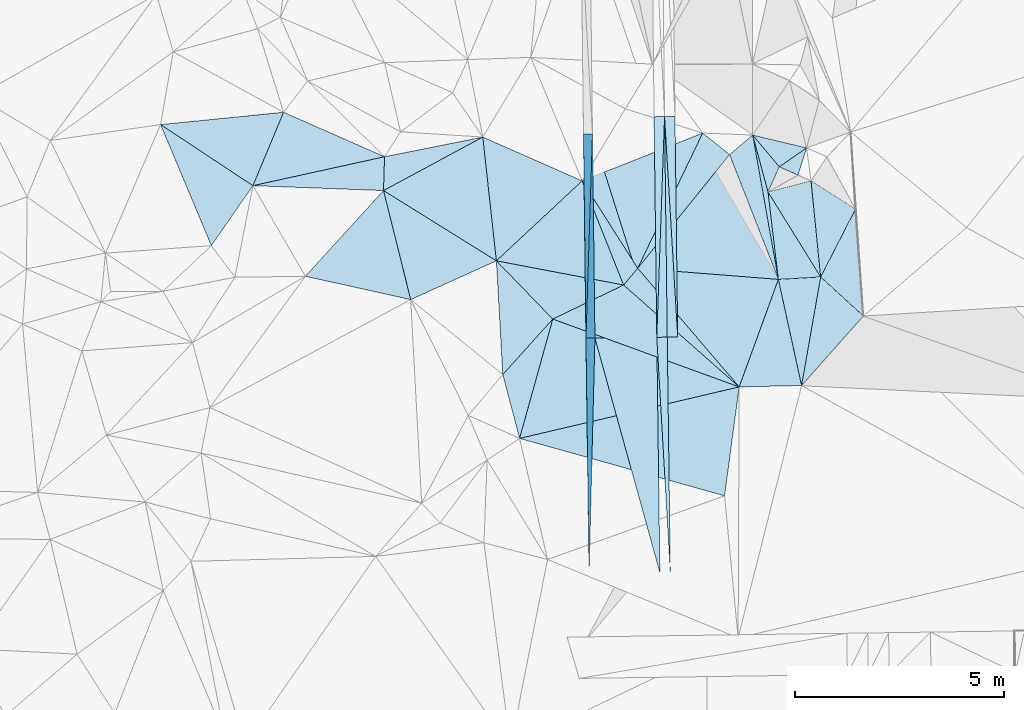
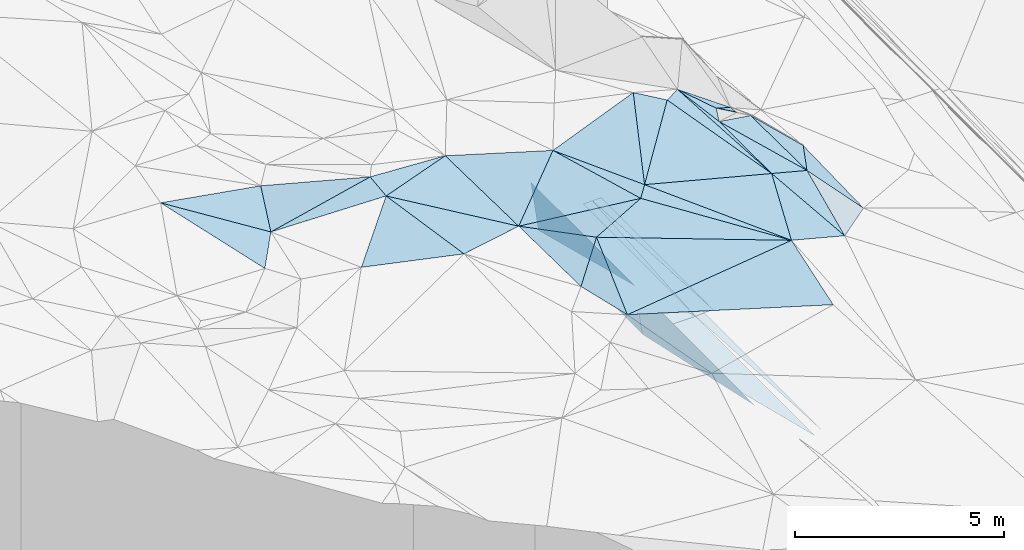
# One storey, part 12 of 275: 45 plates.
"""IFC2X3 building model written with IfcOpenShell, lengths in millimetres."""

from ifc_helpers import new_model, si_unit, frame, origin_with_axes, place, context, subcontext, project, spatial, polyline, outline, extrude, material, type_object, element, save


model = new_model("IFC2X3")

# Units and contexts
model_context = context("Model", 3, precision=1e-05, world=origin_with_axes())
body_context = subcontext(model_context, "Body", "Model", "MODEL_VIEW")
ifc_project = project(units=[si_unit("LENGTHUNIT", "METRE", prefix="MILLI"), si_unit("AREAUNIT", "SQUARE_METRE"), si_unit("VOLUMEUNIT", "CUBIC_METRE"), si_unit("MASSUNIT", "GRAM", prefix="KILO"), si_unit("TIMEUNIT", "SECOND"), si_unit("PLANEANGLEUNIT", "RADIAN"), si_unit("SOLIDANGLEUNIT", "STERADIAN"), si_unit("THERMODYNAMICTEMPERATUREUNIT", "DEGREE_CELSIUS"), si_unit("LUMINOUSINTENSITYUNIT", "LUMEN")], contexts=[model_context])

# Site, building, storey
site_placement = place(None, origin_with_axes())
site = spatial("IfcSite", under=ifc_project, at=site_placement, CompositionType="ELEMENT")
building_placement = place(site_placement, origin_with_axes())
building = spatial("IfcBuilding", under=site, at=building_placement, Name="Undefined", CompositionType="ELEMENT")
storey_placement = place(building_placement, origin_with_axes())
storey = spatial("IfcBuildingStorey", under=building, at=storey_placement, Name="Undefined", CompositionType="ELEMENT", Elevation=0.0)

# Plates
ifc_material = material()
plate_type_1 = type_object("IfcPlateType", PredefinedType="NOTDEFINED")
plate_1_placement = place(storey_placement, frame((-105311.534539102, 6777.27303504071, 42848.6392914802), z_axis=(-0.989907704704984, -0.00910865959501595, -0.141420537709669), x_axis=(0.0304010768781308, 0.961049442663291, -0.274699368913049)))
element("IfcPlate", 1, at=plate_1_placement, inside=storey, type_object=plate_type_1, material=ifc_material, Name="00_PR", context=body_context, shape_type="SweptSolid", body=[
    extrude(outline(polyline([(0.0, 0.0), (5085.4248046875, -1.4915713109076e-09), (421.161773681641, 1455.52087402344), (0.0, 0.0)])), frame((-8.85201319254618e-08, 2.18876761149539e-07, -0.5000001331573), z_axis=(0.0, 0.0, 1.0), x_axis=(1.0, 0.0, 0.0)), (0.0, 0.0, 1.0), 1.0),
])
plate_2_placement = place(storey_placement, frame((-105156.932144304, 11664.6177710189, 41451.6762918623), z_axis=(-0.989907704704984, -0.00910865959501595, -0.141420537709669), x_axis=(-0.03040107687677, -0.961049442663311, 0.274699368913131)))
element("IfcPlate", 2, at=plate_2_placement, inside=storey, type_object=plate_type_1, material=ifc_material, Name="00_PR", context=body_context, shape_type="SweptSolid", body=[
    extrude(outline(polyline([(0.0, 0.0), (5085.4248046875, -1.4915713109076e-09), (420.995239257813, 1455.56896972656), (0.0, 0.0)])), frame((-8.85201319254618e-08, 2.18876761149539e-07, -0.5000001331573), z_axis=(0.0, 0.0, 1.0), x_axis=(1.0, 0.0, 0.0)), (0.0, 0.0, 1.0), 1.0),
])
plate_type_2 = type_object("IfcPlateType", PredefinedType="NOTDEFINED")
plate_3_placement = place(storey_placement, frame((-103681.14404474, 12075.1999108277, 41459.4977358279), z_axis=(0.049675548596903, 0.0216651002195111, -0.998530401792592), x_axis=(0.998683480273055, 0.0117277551140836, 0.0499376209854073)))
element("IfcPlate", 3, at=plate_3_placement, inside=storey, type_object=plate_type_2, material=ifc_material, Name="00_PR", context=body_context, shape_type="SweptSolid", body=[
    extrude(outline(polyline([(0.0, 0.0), (250.312271118164, 1.46246748045087e-09), (-3.24399423599243, 5278.095703125), (0.0, 0.0)])), frame((-8.85201319254618e-08, 2.18876761149539e-07, -0.5000001331573), z_axis=(0.0, 0.0, 1.0), x_axis=(1.0, 0.0, 0.0)), (0.0, 0.0, 1.0), 1.0),
])
plate_4_placement = place(storey_placement, frame((-103431.161307653, 12078.1355123052, 41471.9977351904), z_axis=(0.0496571598516106, 0.0216657678600661, -0.998531301952275), x_axis=(0.0121785501104565, -0.99970349708119, -0.0210855600078803)))
element("IfcPlate", 4, at=plate_4_placement, inside=storey, type_object=plate_type_2, material=ifc_material, Name="00_PR", context=body_context, shape_type="SweptSolid", body=[
    extrude(outline(polyline([(0.0, 0.0), (5277.87744140625, -2.03726813197136e-10), (5278.25048828125, 250.311660766602), (0.0, 0.0)])), frame((-8.85201319254618e-08, 2.18876761149539e-07, -0.5000001331573), z_axis=(0.0, 0.0, 1.0), x_axis=(1.0, 0.0, 0.0)), (0.0, 0.0, 1.0), 1.0),
])
plate_5_placement = place(storey_placement, frame((-103616.864139286, 6798.66814611104, 41348.2107373969), z_axis=(0.0496542488797176, 0.0218785899681712, -0.998526806284737), x_axis=(0.998672792669044, 0.0126047731065468, 0.0499376899500204)))
element("IfcPlate", 5, at=plate_5_placement, inside=storey, type_object=plate_type_2, material=ifc_material, Name="00_PR", context=body_context, shape_type="SweptSolid", body=[
    extrude(outline(polyline([(0.0, 0.0), (250.311935424805, 6.73026079311967e-10), (246.953109741211, 5631.4130859375), (0.0, 0.0)])), frame((-8.85201319254618e-08, 2.18876761149539e-07, -0.5000001331573), z_axis=(0.0, 0.0, 1.0), x_axis=(1.0, 0.0, 0.0)), (0.0, 0.0, 1.0), 1.0),
])
plate_6_placement = place(storey_placement, frame((-103431.196251887, 12078.135100102, 41471.9972120583), z_axis=(-0.020237745679779, 0.0208372426819677, -0.999578032455302), x_axis=(0.999731085484492, 0.0117437361223175, -0.0199960340540243)))
element("IfcPlate", 6, at=plate_6_placement, inside=storey, type_object=plate_type_2, material=ifc_material, Name="00_PR", context=body_context, shape_type="SweptSolid", body=[
    extrude(outline(polyline([(0.0, 0.0), (250.049530029297, -4.94765117764473e-10), (254.571212768555, 5277.65771484375), (0.0, 0.0)])), frame((-8.85201319254618e-08, 2.18876761149539e-07, -0.5000001331573), z_axis=(0.0, 0.0, 1.0), x_axis=(1.0, 0.0, 0.0)), (0.0, 0.0, 1.0), 1.0),
])
plate_7_placement = place(storey_placement, frame((-103116.939240419, 6804.97696331954, 41355.7102121323), z_axis=(-0.0202560501928587, 0.0208361447954981, -0.999577684575164), x_axis=(-0.999720480409342, -0.0126143201234942, 0.0199959990482437)))
element("IfcPlate", 7, at=plate_7_placement, inside=storey, type_object=plate_type_2, material=ifc_material, Name="00_PR", context=body_context, shape_type="SweptSolid", body=[
    extrude(outline(polyline([(0.0, 0.0), (250.050018310547, 2.20097717829049e-10), (249.977157592773, 5277.87744140625), (0.0, 0.0)])), frame((-8.85201319254618e-08, 2.18876761149539e-07, -0.5000001331573), z_axis=(0.0, 0.0, 1.0), x_axis=(1.0, 0.0, 0.0)), (0.0, 0.0, 1.0), 1.0),
])
plate_type_3 = type_object("IfcPlateType", PredefinedType="NOTDEFINED")
plate_8_placement = place(storey_placement, frame((-106899.375949189, 4379.93959712704, 44009.5043430276), z_axis=(0.118877986441834, 0.0572390628680032, -0.991257642604347), x_axis=(-0.254442758458782, 0.966756584332533, 0.0253098660126992)))
element("IfcPlate", 8, at=plate_8_placement, inside=storey, type_object=plate_type_3, material=ifc_material, Name="00", context=body_context, shape_type="SweptSolid", body=[
    extrude(outline(polyline([(0.0, 0.0), (1580.41137695313, -2.11002770811319e-09), (2564.39575195313, 1506.6435546875), (0.0, 0.0)])), frame((-8.85201319254618e-08, 2.18876761149539e-07, -0.5000001331573), z_axis=(0.0, 0.0, 1.0), x_axis=(1.0, 0.0, 0.0)), (0.0, 0.0, 1.0), 1.0),
])
plate_type_4 = type_object("IfcPlateType", PredefinedType="NOTDEFINED")
plate_9_placement = place(storey_placement, frame((-98673.3346984324, 7308.29864070319, 42475.6112736278), z_axis=(-0.626266223391294, 0.0581544191839924, -0.777437252110148), x_axis=(-0.620500105248442, 0.56654435298623, 0.542224229895794)))
element("IfcPlate", 9, at=plate_9_placement, inside=storey, type_object=plate_type_4, material=ifc_material, Name="00", context=body_context, shape_type="SweptSolid", body=[
    extrude(outline(polyline([(0.0, 0.0), (1648.76440429688, 4.05270839110017e-09), (1754.3828125, 1905.32006835938), (0.0, 0.0)])), frame((-8.85201319254618e-08, 2.18876761149539e-07, -0.5000001331573), z_axis=(0.0, 0.0, 1.0), x_axis=(1.0, 0.0, 0.0)), (0.0, 0.0, 1.0), 1.0),
])
plate_type_5 = type_object("IfcPlateType", PredefinedType="NOTDEFINED")
plate_10_placement = place(storey_placement, frame((-103616.889101531, 6798.66775004432, 41348.2101130017), z_axis=(-0.000276400419123975, 0.0210828808791498, -0.999777693158156), x_axis=(-0.301591484977153, 0.953223562598078, 0.0201845459969806)))
element("IfcPlate", 10, at=plate_10_placement, inside=storey, type_object=plate_type_5, material=ifc_material, Name="00_PR", context=body_context, shape_type="SweptSolid", body=[
    extrude(outline(polyline([(0.0, 0.0), (5104.7470703125, 9.18225850909948e-09), (5051.34716796875, 1530.42419433594), (0.0, 0.0)])), frame((-8.85201319254618e-08, 2.18876761149539e-07, -0.5000001331573), z_axis=(0.0, 0.0, 1.0), x_axis=(1.0, 0.0, 0.0)), (0.0, 0.0, 1.0), 1.0),
])
plate_11_placement = place(storey_placement, frame((-105096.771078439, 6779.99218978298, 41348.2101130105), z_axis=(-0.0002660993093648, 0.021086138753576, -0.999777627246991), x_axis=(-0.0122114461021662, 0.999703048210039, 0.0210878160000028)))
element("IfcPlate", 11, at=plate_11_placement, inside=storey, type_object=plate_type_5, material=ifc_material, Name="00_PR", context=body_context, shape_type="SweptSolid", body=[
    extrude(outline(polyline([(0.0, 0.0), (4886.091796875, -2.38651409745216e-09), (0.598517000675201, 1479.99975585938), (0.0, 0.0)])), frame((-8.85201319254618e-08, 2.18876761149539e-07, -0.5000001331573), z_axis=(0.0, 0.0, 1.0), x_axis=(1.0, 0.0, 0.0)), (0.0, 0.0, 1.0), 1.0),
])
plate_12_placement = place(storey_placement, frame((-103543.210280673, 1168.77483800514, 41228.5231136307), z_axis=(-0.000268178566167329, 0.021250884903845, -0.999774138478817), x_axis=(-0.266772507193369, 0.963540364283153, 0.020552270017032)))
element("IfcPlate", 12, at=plate_12_placement, inside=storey, type_object=plate_type_5, material=ifc_material, Name="00_PR", context=body_context, shape_type="SweptSolid", body=[
    extrude(outline(polyline([(0.0, 0.0), (5823.54150390625, 9.89530235528946e-09), (5446.74462890625, 1431.2314453125), (0.0, 0.0)])), frame((-8.85201319254618e-08, 2.18876761149539e-07, -0.5000001331573), z_axis=(0.0, 0.0, 1.0), x_axis=(1.0, 0.0, 0.0)), (0.0, 0.0, 1.0), 1.0),
])
plate_type_6 = type_object("IfcPlateType", PredefinedType="NOTDEFINED")
plate_13_placement = place(storey_placement, frame((-105097.265896179, 6779.97667364757, 41348.6392917075), z_axis=(-0.989899562754256, -0.00994924521578573, -0.141420890177402), x_axis=(-0.0242256038924693, -0.970991788057475, 0.237882466022597)))
element("IfcPlate", 13, at=plate_13_placement, inside=storey, type_object=plate_type_6, material=ifc_material, Name="00_PR", context=body_context, shape_type="SweptSolid", body=[
    extrude(outline(polyline([(0.0, 0.0), (5802.5, -2.25554686039686e-09), (364.640106201172, 1470.69909667969), (0.0, 0.0)])), frame((-8.85201319254618e-08, 2.18876761149539e-07, -0.5000001331573), z_axis=(0.0, 0.0, 1.0), x_axis=(1.0, 0.0, 0.0)), (0.0, 0.0, 1.0), 1.0),
])
plate_type_7 = type_object("IfcPlateType", PredefinedType="NOTDEFINED")
plate_14_placement = place(storey_placement, frame((-101322.069498458, 11637.9859883481, 44252.5355389453), z_axis=(-0.358408016384368, 0.0933613736969055, -0.928885002404953), x_axis=(0.172632840587883, -0.971199400939211, -0.164224316000632)))
element("IfcPlate", 14, at=plate_14_placement, inside=storey, type_object=plate_type_7, material=ifc_material, Name="00", context=body_context, shape_type="SweptSolid", body=[
    extrude(outline(polyline([(0.0, 0.0), (3556.11157226563, -4.51109372079372e-10), (330.488220214844, 666.552001953125), (0.0, 0.0)])), frame((-8.85201319254618e-08, 2.18876761149539e-07, -0.5000001331573), z_axis=(0.0, 0.0, 1.0), x_axis=(1.0, 0.0, 0.0)), (0.0, 0.0, 1.0), 1.0),
])
plate_type_8 = type_object("IfcPlateType", PredefinedType="NOTDEFINED")
plate_15_placement = place(storey_placement, frame((-100238.779923733, 10681.1407174191, 43779.5720859319), z_axis=(-0.431166749436411, -0.285802984600366, -0.855810661404707), x_axis=(-0.870555178164331, 0.381052098901154, 0.311340616839973)))
element("IfcPlate", 15, at=plate_15_placement, inside=storey, type_object=plate_type_8, material=ifc_material, Name="00", context=body_context, shape_type="SweptSolid", body=[
    extrude(outline(polyline([(0.0, 0.0), (513.906616210938, 2.33558239415288e-09), (-31.328649520874, 751.011657714844), (0.0, 0.0)])), frame((-8.85201319254618e-08, 2.18876761149539e-07, -0.5000001331573), z_axis=(0.0, 0.0, 1.0), x_axis=(1.0, 0.0, 0.0)), (0.0, 0.0, 1.0), 1.0),
])
plate_type_9 = type_object("IfcPlateType", PredefinedType="NOTDEFINED")
plate_16_placement = place(storey_placement, frame((-107454.73803149, 8628.23388524601, 44219.5169216005), z_axis=(-0.250251994899827, 0.0634599074432098, -0.966098741949267), x_axis=(-0.891731081506079, -0.403743291430855, 0.204467681799787)))
element("IfcPlate", 16, at=plate_16_placement, inside=storey, type_object=plate_type_9, material=ifc_material, Name="00", context=body_context, shape_type="SweptSolid", body=[
    extrude(outline(polyline([(0.0, 0.0), (2298.65185546875, -1.21726770885289e-08), (1894.84985351563, 2680.79174804688), (0.0, 0.0)])), frame((-8.85201319254618e-08, 2.18876761149539e-07, -0.5000001331573), z_axis=(0.0, 0.0, 1.0), x_axis=(1.0, 0.0, 0.0)), (0.0, 0.0, 1.0), 1.0),
])
plate_type_10 = type_object("IfcPlateType", PredefinedType="NOTDEFINED")
plate_17_placement = place(storey_placement, frame((-100686.218178498, 10877.0550810528, 43939.5824616789), z_axis=(-0.539563084883728, -0.107457671201689, -0.83505959447854), x_axis=(-0.611580337436182, 0.731684808238326, 0.301009687974806)))
element("IfcPlate", 17, at=plate_17_placement, inside=storey, type_object=plate_type_10, material=ifc_material, Name="00", context=body_context, shape_type="SweptSolid", body=[
    extrude(outline(polyline([(0.0, 0.0), (1039.83361816406, 3.23052518069744e-09), (-212.543609619141, 903.396484375), (0.0, 0.0)])), frame((-8.85201319254618e-08, 2.18876761149539e-07, -0.5000001331573), z_axis=(0.0, 0.0, 1.0), x_axis=(1.0, 0.0, 0.0)), (0.0, 0.0, 1.0), 1.0),
])
plate_type_11 = type_object("IfcPlateType", PredefinedType="NOTDEFINED")
plate_18_placement = place(storey_placement, frame((-105402.89860283, 10541.1997784355, 44559.5023324568), z_axis=(0.00287089548697418, 0.097012839862263, -0.995278989460223), x_axis=(0.534646845404207, -0.841236964478008, -0.0804557039317723)))
element("IfcPlate", 18, at=plate_18_placement, inside=storey, type_object=plate_type_11, material=ifc_material, Name="00", context=body_context, shape_type="SweptSolid", body=[
    extrude(outline(polyline([(0.0, 0.0), (2485.83984375, -6.21366780251265e-09), (2645.78588867188, 499.817260742188), (0.0, 0.0)])), frame((-8.85201319254618e-08, 2.18876761149539e-07, -0.5000001331573), z_axis=(0.0, 0.0, 1.0), x_axis=(1.0, 0.0, 0.0)), (0.0, 0.0, 1.0), 1.0),
])
plate_type_12 = type_object("IfcPlateType", PredefinedType="NOTDEFINED")
plate_19_placement = place(storey_placement, frame((-100708.039436247, 8184.31991708845, 43668.5081416252), z_axis=(-0.10176336654217, 0.148249486077847, -0.983700313666545), x_axis=(-0.172632840193338, 0.971199401024251, 0.164224315912468)))
element("IfcPlate", 19, at=plate_19_placement, inside=storey, type_object=plate_type_12, material=ifc_material, Name="00", context=body_context, shape_type="SweptSolid", body=[
    extrude(outline(polyline([(0.0, 0.0), (3556.11157226563, -4.51109372079372e-10), (2130.89672851563, 122.134048461914), (0.0, 0.0)])), frame((-8.85201319254618e-08, 2.18876761149539e-07, -0.5000001331573), z_axis=(0.0, 0.0, 1.0), x_axis=(1.0, 0.0, 0.0)), (0.0, 0.0, 1.0), 1.0),
])
plate_type_13 = type_object("IfcPlateType", PredefinedType="NOTDEFINED")
plate_20_placement = place(storey_placement, frame((-99696.2502533209, 8242.40960016099, 43369.5317261071), z_axis=(-0.340428152315741, 0.0837690067391531, -0.936531594032378), x_axis=(-0.508731502324898, 0.821238178169803, 0.258379784926366)))
element("IfcPlate", 20, at=plate_20_placement, inside=storey, type_object=plate_type_13, material=ifc_material, Name="00", context=body_context, shape_type="SweptSolid", body=[
    extrude(outline(polyline([(0.0, 0.0), (2476.97387695313, 5.6170392781496e-09), (2083.99438476563, 1048.55480957031), (0.0, 0.0)])), frame((-8.85201319254618e-08, 2.18876761149539e-07, -0.5000001331573), z_axis=(0.0, 0.0, 1.0), x_axis=(1.0, 0.0, 0.0)), (0.0, 0.0, 1.0), 1.0),
])
plate_type_14 = type_object("IfcPlateType", PredefinedType="NOTDEFINED")
plate_21_placement = place(storey_placement, frame((-100152.939018249, 5644.94776319653, 43192.5216678955), z_axis=(-0.264801575882705, 0.121424983426986, -0.956627460827773), x_axis=(-0.964235945462771, -0.021649415538222, 0.264159694662847)))
element("IfcPlate", 21, at=plate_21_placement, inside=storey, type_object=plate_type_14, material=ifc_material, Name="00", context=body_context, shape_type="SweptSolid", body=[
    extrude(outline(polyline([(0.0, 0.0), (1548.30590820313, 5.05679054185748e-09), (606.0908203125, 2572.11962890625), (0.0, 0.0)])), frame((-8.85201319254618e-08, 2.18876761149539e-07, -0.5000001331573), z_axis=(0.0, 0.0, 1.0), x_axis=(1.0, 0.0, 0.0)), (0.0, 0.0, 1.0), 1.0),
])
plate_type_15 = type_object("IfcPlateType", PredefinedType="NOTDEFINED")
plate_22_placement = place(storey_placement, frame((-100956.384255378, 10276.5847810361, 44009.5383786055), z_axis=(-0.379064172914386, 0.0629665458802271, -0.9232256316376), x_axis=(-0.255652731098491, 0.951726404651745, 0.169877990836204)))
element("IfcPlate", 22, at=plate_22_placement, inside=storey, type_object=plate_type_15, material=ifc_material, Name="00", context=body_context, shape_type="SweptSolid", body=[
    extrude(outline(polyline([(0.0, 0.0), (1430.43835449219, -1.17870513349772e-09), (490.583862304688, 444.890411376953), (0.0, 0.0)])), frame((-8.85201319254618e-08, 2.18876761149539e-07, -0.5000001331573), z_axis=(0.0, 0.0, 1.0), x_axis=(1.0, 0.0, 0.0)), (0.0, 0.0, 1.0), 1.0),
])
plate_type_16 = type_object("IfcPlateType", PredefinedType="NOTDEFINED")
plate_23_placement = place(storey_placement, frame((-102519.152049901, 11684.9191982441, 44549.5061837628), z_axis=(-0.110783938408556, 0.111251216509545, -0.987598139840206), x_axis=(0.77140163336825, -0.616923780432751, -0.156027462881888)))
element("IfcPlate", 23, at=plate_23_placement, inside=storey, type_object=plate_type_16, material=ifc_material, Name="00", context=body_context, shape_type="SweptSolid", body=[
    extrude(outline(polyline([(0.0, 0.0), (833.186645507813, 2.25554686039686e-10), (825.985412597656, 3497.94921875), (0.0, 0.0)])), frame((-8.85201319254618e-08, 2.18876761149539e-07, -0.5000001331573), z_axis=(0.0, 0.0, 1.0), x_axis=(1.0, 0.0, 0.0)), (0.0, 0.0, 1.0), 1.0),
])
plate_type_17 = type_object("IfcPlateType", PredefinedType="NOTDEFINED")
plate_24_placement = place(storey_placement, frame((-110130.235532706, 11119.0642143201, 45089.5013637645), z_axis=(0.0123268294845498, 0.0735623200279889, -0.997214437494243), x_axis=(-0.0307243713770341, -0.996791447861311, -0.0739109090326888)))
element("IfcPlate", 24, at=plate_24_placement, inside=storey, type_object=plate_type_17, material=ifc_material, Name="00", context=body_context, shape_type="SweptSolid", body=[
    extrude(outline(polyline([(0.0, 0.0), (811.788146972656, 4.94765117764473e-10), (793.556762695313, 3126.2705078125), (0.0, 0.0)])), frame((-8.85201319254618e-08, 2.18876761149539e-07, -0.5000001331573), z_axis=(0.0, 0.0, 1.0), x_axis=(1.0, 0.0, 0.0)), (0.0, 0.0, 1.0), 1.0),
])
plate_type_18 = type_object("IfcPlateType", PredefinedType="NOTDEFINED")
plate_25_placement = place(storey_placement, frame((-99927.4203669078, 10545.6507572962, 43659.6016722024), z_axis=(-0.603143476425068, 0.0398025700156765, -0.79663900373132), x_axis=(0.702389133977225, -0.446780994797186, -0.554108515688723)))
element("IfcPlate", 25, at=plate_25_placement, inside=storey, type_object=plate_type_18, material=ifc_material, Name="00", context=body_context, shape_type="SweptSolid", body=[
    extrude(outline(polyline([(0.0, 0.0), (1515.94860839844, -7.26140569895506e-09), (1352.02478027344, 1901.19152832031), (0.0, 0.0)])), frame((-8.85201319254618e-08, 2.18876761149539e-07, -0.5000001331573), z_axis=(0.0, 0.0, 1.0), x_axis=(1.0, 0.0, 0.0)), (0.0, 0.0, 1.0), 1.0),
])
plate_type_19 = type_object("IfcPlateType", PredefinedType="NOTDEFINED")
plate_26_placement = place(storey_placement, frame((-107779.911550304, 11589.6351528228, 44599.513654365), z_axis=(-0.218553867247165, 0.0788561700006157, -0.972633492927394), x_axis=(-0.869391685502058, -0.468390336414707, 0.15738039882148)))
element("IfcPlate", 26, at=plate_26_placement, inside=storey, type_object=plate_type_19, material=ifc_material, Name="00", context=body_context, shape_type="SweptSolid", body=[
    extrude(outline(polyline([(0.0, 0.0), (2732.2333984375, 7.53789208829403e-09), (2340.978515625, 711.280212402344), (0.0, 0.0)])), frame((-8.85201319254618e-08, 2.18876761149539e-07, -0.5000001331573), z_axis=(0.0, 0.0, 1.0), x_axis=(1.0, 0.0, 0.0)), (0.0, 0.0, 1.0), 1.0),
])
plate_type_20 = type_object("IfcPlateType", PredefinedType="NOTDEFINED")
plate_27_placement = place(storey_placement, frame((-99696.3631426029, 8242.44507972654, 43369.5951862125), z_axis=(-0.566205723425485, 0.154727751885412, -0.809611265705159), x_axis=(0.620500105249706, -0.566544352987563, -0.542224229892955)))
element("IfcPlate", 27, at=plate_27_placement, inside=storey, type_object=plate_type_20, material=ifc_material, Name="00", context=body_context, shape_type="SweptSolid", body=[
    extrude(outline(polyline([(0.0, 0.0), (1648.76440429688, 4.05270839110017e-09), (1284.16284179688, 2310.35913085938), (0.0, 0.0)])), frame((-8.85201319254618e-08, 2.18876761149539e-07, -0.5000001331573), z_axis=(0.0, 0.0, 1.0), x_axis=(1.0, 0.0, 0.0)), (0.0, 0.0, 1.0), 1.0),
])
plate_type_21 = type_object("IfcPlateType", PredefinedType="NOTDEFINED")
plate_28_placement = place(storey_placement, frame((-107454.559423281, 8628.2361714643, 44219.5040195692), z_axis=(0.107050397893271, 0.068008536030492, -0.991924922228432), x_axis=(0.695183663893955, -0.718369995981389, 0.0257725111053699)))
element("IfcPlate", 28, at=plate_28_placement, inside=storey, type_object=plate_type_21, material=ifc_material, Name="00", context=body_context, shape_type="SweptSolid", body=[
    extrude(outline(polyline([(0.0, 0.0), (1940.05151367188, 5.0495145842433e-09), (2056.28564453125, 1795.74206542969), (0.0, 0.0)])), frame((-8.85201319254618e-08, 2.18876761149539e-07, -0.5000001331573), z_axis=(0.0, 0.0, 1.0), x_axis=(1.0, 0.0, 0.0)), (0.0, 0.0, 1.0), 1.0),
])
plate_type_22 = type_object("IfcPlateType", PredefinedType="NOTDEFINED")
plate_29_placement = place(storey_placement, frame((-100152.950401821, 5644.94472752284, 43192.5245871119), z_axis=(-0.287565944820449, 0.11535354525011, -0.950788823544826), x_axis=(-0.21009215455279, 0.960944933764837, 0.18012806796016)))
element("IfcPlate", 29, at=plate_29_placement, inside=storey, type_object=plate_type_22, material=ifc_material, Name="00", context=body_context, shape_type="SweptSolid", body=[
    extrude(outline(polyline([(0.0, 0.0), (2642.56420898438, 7.71251507103443e-10), (2431.9638671875, 1035.56042480469), (0.0, 0.0)])), frame((-8.85201319254618e-08, 2.18876761149539e-07, -0.5000001331573), z_axis=(0.0, 0.0, 1.0), x_axis=(1.0, 0.0, 0.0)), (0.0, 0.0, 1.0), 1.0),
])
plate_type_23 = type_object("IfcPlateType", PredefinedType="NOTDEFINED")
plate_30_placement = place(storey_placement, frame((-104410.703975727, 8049.56722336791, 44319.5002318033), z_axis=(0.0318846638023713, -0.00500213999710401, -0.999479037703973), x_axis=(-0.900925460907784, -0.433159553634864, -0.026572824143154)))
element("IfcPlate", 30, at=plate_30_placement, inside=storey, type_object=plate_type_23, material=ifc_material, Name="00", context=body_context, shape_type="SweptSolid", body=[
    extrude(outline(polyline([(0.0, 0.0), (1881.62158203125, -1.03900674730539e-08), (2494.337890625, 1840.75500488281), (0.0, 0.0)])), frame((-8.85201319254618e-08, 2.18876761149539e-07, -0.5000001331573), z_axis=(0.0, 0.0, 1.0), x_axis=(1.0, 0.0, 0.0)), (0.0, 0.0, 1.0), 1.0),
])
plate_type_24 = type_object("IfcPlateType", PredefinedType="NOTDEFINED")
plate_31_placement = place(storey_placement, frame((-99696.2239599939, 8242.42809552482, 43369.5249359947), z_axis=(-0.287668091113385, 0.120718513487861, -0.950091632347355), x_axis=(-0.957559133327413, -0.0550002085666582, 0.282940776910784)))
element("IfcPlate", 31, at=plate_31_placement, inside=storey, type_object=plate_type_24, material=ifc_material, Name="00", context=body_context, shape_type="SweptSolid", body=[
    extrude(outline(polyline([(0.0, 0.0), (1056.75830078125, -5.71526470594108e-09), (1275.83581542969, 2123.12109375), (0.0, 0.0)])), frame((-8.85201319254618e-08, 2.18876761149539e-07, -0.5000001331573), z_axis=(0.0, 0.0, 1.0), x_axis=(1.0, 0.0, 0.0)), (0.0, 0.0, 1.0), 1.0),
])
plate_type_25 = type_object("IfcPlateType", PredefinedType="NOTDEFINED")
plate_32_placement = place(storey_placement, frame((-104410.692474105, 8049.62840952679, 44319.5041863406), z_axis=(0.0548871623162619, 0.117369166394397, -0.991570410103465), x_axis=(-0.981895854534504, 0.186654651482314, -0.0322578971412091)))
element("IfcPlate", 32, at=plate_32_placement, inside=storey, type_object=plate_type_25, material=ifc_material, Name="00", context=body_context, shape_type="SweptSolid", body=[
    extrude(outline(polyline([(0.0, 0.0), (3100.01611328125, 9.32413968257606e-09), (1431.54089355469, 2280.50219726563), (0.0, 0.0)])), frame((-8.85201319254618e-08, 2.18876761149539e-07, -0.5000001331573), z_axis=(0.0, 0.0, 1.0), x_axis=(1.0, 0.0, 0.0)), (0.0, 0.0, 1.0), 1.0),
])
plate_type_26 = type_object("IfcPlateType", PredefinedType="NOTDEFINED")
plate_33_placement = place(storey_placement, frame((-104073.950039461, 8450.01873384058, 44359.5117055336), z_axis=(-0.192919817678208, 0.0957442103405234, -0.976532124475829), x_axis=(0.976654131708035, -0.0771039473676926, -0.200503586795711)))
element("IfcPlate", 33, at=plate_33_placement, inside=storey, type_object=plate_type_26, material=ifc_material, Name="00", context=body_context, shape_type="SweptSolid", body=[
    extrude(outline(polyline([(0.0, 0.0), (3446.32250976563, -1.1098563845735e-08), (2742.27758789063, 2647.24194335938), (0.0, 0.0)])), frame((-8.85201319254618e-08, 2.18876761149539e-07, -0.5000001331573), z_axis=(0.0, 0.0, 1.0), x_axis=(1.0, 0.0, 0.0)), (0.0, 0.0, 1.0), 1.0),
])
plate_type_27 = type_object("IfcPlateType", PredefinedType="NOTDEFINED")
plate_34_placement = place(storey_placement, frame((-112546.834517471, 12182.8389268325, 45029.5187186239), z_axis=(-0.244129381651212, 0.118266914043218, -0.962503912749081), x_axis=(-0.384902091329228, -0.922822765980292, -0.0157646020840735)))
element("IfcPlate", 34, at=plate_34_placement, inside=storey, type_object=plate_type_27, material=ifc_material, Name="00", context=body_context, shape_type="SweptSolid", body=[
    extrude(outline(polyline([(0.0, 0.0), (1902.99768066406, 4.10364009439945e-09), (1393.22290039063, 2702.87426757813), (0.0, 0.0)])), frame((-8.85201319254618e-08, 2.18876761149539e-07, -0.5000001331573), z_axis=(0.0, 0.0, 1.0), x_axis=(1.0, 0.0, 0.0)), (0.0, 0.0, 1.0), 1.0),
])
plate_type_28 = type_object("IfcPlateType", PredefinedType="NOTDEFINED")
plate_35_placement = place(storey_placement, frame((-101645.786936315, 5611.45660162848, 43601.5104125406), z_axis=(-0.096446995642583, 0.178956721677644, -0.97911820981836), x_axis=(-0.736204207457864, 0.649196099572995, 0.191174760940215)))
element("IfcPlate", 35, at=plate_35_placement, inside=storey, type_object=plate_type_28, material=ifc_material, Name="00", context=body_context, shape_type="SweptSolid", body=[
    extrude(outline(polyline([(0.0, 0.0), (3755.72583007813, -1.90848368220031e-08), (3775.30932617188, 524.420166015625), (0.0, 0.0)])), frame((-8.85201319254618e-08, 2.18876761149539e-07, -0.5000001331573), z_axis=(0.0, 0.0, 1.0), x_axis=(1.0, 0.0, 0.0)), (0.0, 0.0, 1.0), 1.0),
])
plate_type_29 = type_object("IfcPlateType", PredefinedType="NOTDEFINED")
plate_36_placement = place(storey_placement, frame((-101876.46765877, 11170.9363494947, 44419.5161065221), z_axis=(-0.185179735338343, 0.170897767210733, -0.967730550712546), x_axis=(0.354725910643194, -0.906742951926296, -0.228006025030797)))
element("IfcPlate", 36, at=plate_36_placement, inside=storey, type_object=plate_type_29, material=ifc_material, Name="00", context=body_context, shape_type="SweptSolid", body=[
    extrude(outline(polyline([(0.0, 0.0), (3293.77270507813, 4.33647073805332e-09), (1701.31665039063, 3056.34130859375), (0.0, 0.0)])), frame((-8.85201319254618e-08, 2.18876761149539e-07, -0.5000001331573), z_axis=(0.0, 0.0, 1.0), x_axis=(1.0, 0.0, 0.0)), (0.0, 0.0, 1.0), 1.0),
])
plate_type_30 = type_object("IfcPlateType", PredefinedType="NOTDEFINED")
plate_37_placement = place(storey_placement, frame((-110155.199469361, 10309.9045624227, 45029.5039194873), z_axis=(-0.0321820030728838, 0.121228620482935, -0.992102787141545), x_axis=(0.240052862669518, -0.962624584105315, -0.125413449040517)))
element("IfcPlate", 37, at=plate_37_placement, inside=storey, type_object=plate_type_30, material=ifc_material, Name="00", context=body_context, shape_type="SweptSolid", body=[
    extrude(outline(polyline([(0.0, 0.0), (2711.03295898438, 1.01863406598568e-09), (1549.59387207031, 2311.02978515625), (0.0, 0.0)])), frame((-8.85201319254618e-08, 2.18876761149539e-07, -0.5000001331573), z_axis=(0.0, 0.0, 1.0), x_axis=(1.0, 0.0, 0.0)), (0.0, 0.0, 1.0), 1.0),
])
plate_38_placement = place(storey_placement, frame((-105402.879339181, 10541.2170891411, 44559.5047556066), z_axis=(0.0413966767688224, 0.13163614563228, -0.990433359855965), x_axis=(-0.726093784158543, -0.676985794052947, -0.120324774077613)))
element("IfcPlate", 38, at=plate_38_placement, inside=storey, type_object=plate_type_30, material=ifc_material, Name="00", context=body_context, shape_type="SweptSolid", body=[
    extrude(outline(polyline([(0.0, 0.0), (2825.68579101563, -8.58562998473644e-10), (1011.25897216797, 2393.2939453125), (0.0, 0.0)])), frame((-8.85201319254618e-08, 2.18876761149539e-07, -0.5000001331573), z_axis=(0.0, 0.0, 1.0), x_axis=(1.0, 0.0, 0.0)), (0.0, 0.0, 1.0), 1.0),
])
plate_type_31 = type_object("IfcPlateType", PredefinedType="NOTDEFINED")
plate_39_placement = place(storey_placement, frame((-107779.916637785, 11589.6453001737, 44599.5157567939), z_axis=(-0.228726293902936, 0.0991504195826286, -0.968428353970502), x_axis=(0.108276216632434, -0.98603620204161, -0.126526160042592)))
element("IfcPlate", 39, at=plate_39_placement, inside=storey, type_object=plate_type_31, material=ifc_material, Name="00", context=body_context, shape_type="SweptSolid", body=[
    extrude(outline(polyline([(0.0, 0.0), (3003.33154296875, -5.28234522789717e-09), (950.278076171875, 2561.65405273438), (0.0, 0.0)])), frame((-8.85201319254618e-08, 2.18876761149539e-07, -0.5000001331573), z_axis=(0.0, 0.0, 1.0), x_axis=(1.0, 0.0, 0.0)), (0.0, 0.0, 1.0), 1.0),
])
plate_type_32 = type_object("IfcPlateType", PredefinedType="NOTDEFINED")
plate_40_placement = place(storey_placement, frame((-115488.887690267, 11888.0549007793, 45739.5198218824), z_axis=(-0.266019143707704, 0.0840518309363356, -0.960296363055317), x_axis=(0.803327609185579, -0.531302730380074, -0.269039329858778)))
element("IfcPlate", 40, at=plate_40_placement, inside=storey, type_object=plate_type_32, material=ifc_material, Name="00", context=body_context, shape_type="SweptSolid", body=[
    extrude(outline(polyline([(0.0, 0.0), (2750.52734375, -8.9130480773747e-09), (2673.3056640625, 1750.63903808594), (0.0, 0.0)])), frame((-8.85201319254618e-08, 2.18876761149539e-07, -0.5000001331573), z_axis=(0.0, 0.0, 1.0), x_axis=(1.0, 0.0, 0.0)), (0.0, 0.0, 1.0), 1.0),
])
plate_type_33 = type_object("IfcPlateType", PredefinedType="NOTDEFINED")
plate_41_placement = place(storey_placement, frame((-102519.113090793, 11684.9007495797, 44549.5016291004), z_axis=(-0.0329545680169962, 0.0743785329973703, -0.996685421924076), x_axis=(-0.43258011540708, -0.900044372189196, -0.0528637100944801)))
element("IfcPlate", 41, at=plate_41_placement, inside=storey, type_object=plate_type_33, material=ifc_material, Name="00", context=body_context, shape_type="SweptSolid", body=[
    extrude(outline(polyline([(0.0, 0.0), (3594.14794921875, -1.19325704872608e-09), (2276.33911132813, 2107.79028320313), (0.0, 0.0)])), frame((-8.85201319254618e-08, 2.18876761149539e-07, -0.5000001331573), z_axis=(0.0, 0.0, 1.0), x_axis=(1.0, 0.0, 0.0)), (0.0, 0.0, 1.0), 1.0),
])
plate_type_34 = type_object("IfcPlateType", PredefinedType="NOTDEFINED")
plate_42_placement = place(storey_placement, frame((-106899.483536042, 4379.95207285851, 44009.5039948584), z_axis=(-0.0962999990970524, 0.0821905919093737, -0.991953132348245), x_axis=(0.970840179619645, 0.227563024538348, -0.0753950628294441)))
element("IfcPlate", 42, at=plate_42_placement, inside=storey, type_object=plate_type_34, material=ifc_material, Name="00", context=body_context, shape_type="SweptSolid", body=[
    extrude(outline(polyline([(0.0, 0.0), (5411.4951171875, -7.45421857573092e-09), (4493.21875, 2470.13891601563), (0.0, 0.0)])), frame((-8.85201319254618e-08, 2.18876761149539e-07, -0.5000001331573), z_axis=(0.0, 0.0, 1.0), x_axis=(1.0, 0.0, 0.0)), (0.0, 0.0, 1.0), 1.0),
])
plate_type_35 = type_object("IfcPlateType", PredefinedType="NOTDEFINED")
plate_43_placement = place(storey_placement, frame((-113279.166563922, 10426.6530914986, 44999.5001656692), z_axis=(0.0273207939312685, 0.00568108247297882, -0.99961057393412), x_axis=(0.384902091328643, 0.922822765980104, 0.0157646021093592)))
element("IfcPlate", 43, at=plate_43_placement, inside=storey, type_object=plate_type_35, material=ifc_material, Name="00", context=body_context, shape_type="SweptSolid", body=[
    extrude(outline(polyline([(0.0, 0.0), (1902.99768066406, 4.10364009439945e-09), (1852.39331054688, 2640.44287109375), (0.0, 0.0)])), frame((-8.85201319254618e-08, 2.18876761149539e-07, -0.5000001331573), z_axis=(0.0, 0.0, 1.0), x_axis=(1.0, 0.0, 0.0)), (0.0, 0.0, 1.0), 1.0),
])
plate_type_36 = type_object("IfcPlateType", PredefinedType="NOTDEFINED")
plate_44_placement = place(storey_placement, frame((-101645.774145858, 5611.4706728491, 43601.5121022076), z_axis=(-0.0707802564432016, 0.207074894041566, -0.975761314848826), x_axis=(-0.930536387974515, 0.338643046281293, 0.139366128814245)))
element("IfcPlate", 44, at=plate_44_placement, inside=storey, type_object=plate_type_36, material=ifc_material, Name="00", context=body_context, shape_type="SweptSolid", body=[
    extrude(outline(polyline([(0.0, 0.0), (4793.13037109375, 1.35951268021017e-08), (3498.66088867188, 1365.59484863281), (0.0, 0.0)])), frame((-8.85201319254618e-08, 2.18876761149539e-07, -0.5000001331573), z_axis=(0.0, 0.0, 1.0), x_axis=(1.0, 0.0, 0.0)), (0.0, 0.0, 1.0), 1.0),
])
plate_type_37 = type_object("IfcPlateType", PredefinedType="NOTDEFINED")
plate_45_placement = place(storey_placement, frame((-106105.973110776, 7234.58684519144, 44269.5062943226), z_axis=(-0.104572046381364, 0.118998908539997, -0.987372243321587), x_axis=(0.93053638794555, -0.338643046372389, -0.139366128786289)))
element("IfcPlate", 45, at=plate_45_placement, inside=storey, type_object=plate_type_37, material=ifc_material, Name="00", context=body_context, shape_type="SweptSolid", body=[
    extrude(outline(polyline([(0.0, 0.0), (4793.13037109375, 1.35951268021017e-08), (264.536926269531, 2962.45166015625), (0.0, 0.0)])), frame((-8.85201319254618e-08, 2.18876761149539e-07, -0.5000001331573), z_axis=(0.0, 0.0, 1.0), x_axis=(1.0, 0.0, 0.0)), (0.0, 0.0, 1.0), 1.0),
])

save(model, "model.ifc")
